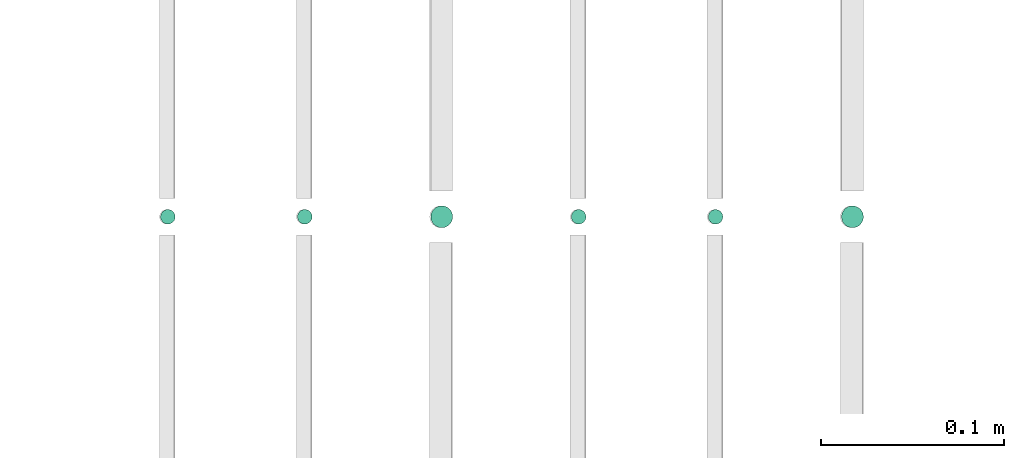
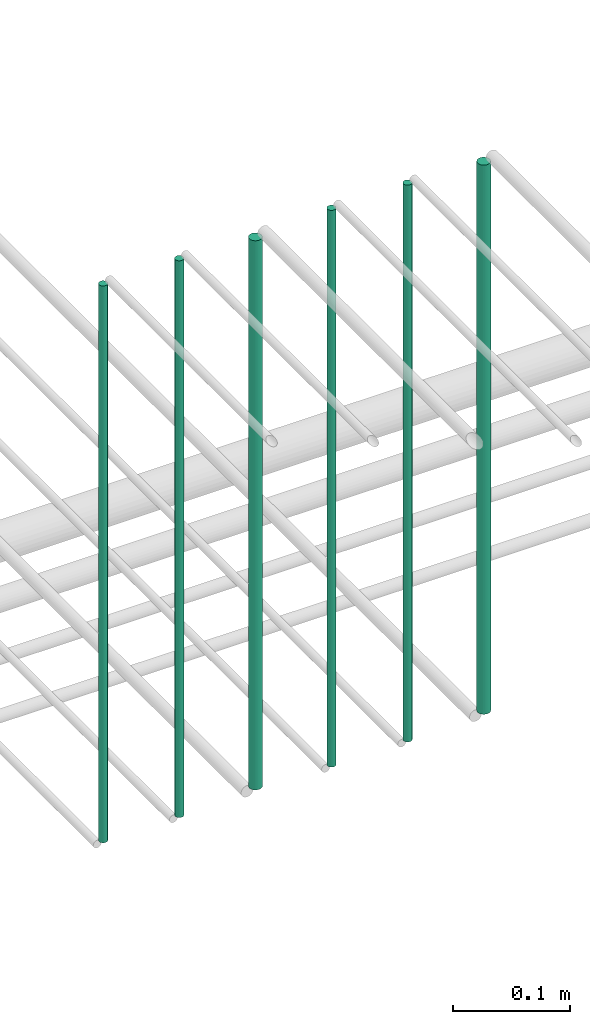
# One storey, part 194 of 331: 6 flow segments.
"""IFC2X3 building model written with IfcOpenShell, lengths in millimetres."""

from ifc_helpers import new_model, entity, si_unit, converted_unit, derived_unit, direction, frame, origin, origin_2d_with_axis, place, context, subcontext, project, spatial, circle, extrude, type_object, element, save


model = new_model("IFC2X3")

# Units and contexts
model_context = context("Model", 3, precision=0.01, world=origin(), true_north=direction((6.12303176911189e-17, 1.0)))
body_context = subcontext(model_context, "Body", "Model", "MODEL_VIEW")
ifc_project = project(units=[si_unit("LENGTHUNIT", "METRE", prefix="MILLI"), si_unit("AREAUNIT", "SQUARE_METRE"), si_unit("VOLUMEUNIT", "CUBIC_METRE"), converted_unit("PLANEANGLEUNIT", "DEGREE", entity("IfcRatioMeasure", 0.0174532925199433), si_unit("PLANEANGLEUNIT", "RADIAN"), dimensions=[0, 0, 0, 0, 0, 0, 0]), si_unit("MASSUNIT", "GRAM", prefix="KILO"), derived_unit("MASSDENSITYUNIT", [(si_unit("MASSUNIT", "GRAM", prefix="KILO"), 1), (si_unit("LENGTHUNIT", "METRE"), -3)]), derived_unit("MOMENTOFINERTIAUNIT", [(si_unit("LENGTHUNIT", "METRE"), 4)]), si_unit("TIMEUNIT", "SECOND"), si_unit("FREQUENCYUNIT", "HERTZ"), si_unit("THERMODYNAMICTEMPERATUREUNIT", "DEGREE_CELSIUS"), derived_unit("THERMALTRANSMITTANCEUNIT", [(si_unit("MASSUNIT", "GRAM", prefix="KILO"), 1), (si_unit("THERMODYNAMICTEMPERATUREUNIT", "KELVIN"), -1), (si_unit("TIMEUNIT", "SECOND"), -3)]), derived_unit("VOLUMETRICFLOWRATEUNIT", [(si_unit("LENGTHUNIT", "METRE"), 3), (si_unit("TIMEUNIT", "SECOND"), -1)]), derived_unit("MASSFLOWRATEUNIT", [(si_unit("MASSUNIT", "GRAM", prefix="KILO"), 1), (si_unit("TIMEUNIT", "SECOND"), -1)]), derived_unit("ROTATIONALFREQUENCYUNIT", [(si_unit("TIMEUNIT", "SECOND"), -1)]), si_unit("ELECTRICCURRENTUNIT", "AMPERE"), si_unit("ELECTRICVOLTAGEUNIT", "VOLT"), si_unit("POWERUNIT", "WATT"), si_unit("FORCEUNIT", "NEWTON", prefix="KILO"), si_unit("ILLUMINANCEUNIT", "LUX"), si_unit("LUMINOUSFLUXUNIT", "LUMEN"), si_unit("LUMINOUSINTENSITYUNIT", "CANDELA"), derived_unit("USERDEFINED", [(si_unit("MASSUNIT", "GRAM", prefix="KILO"), -1), (si_unit("LENGTHUNIT", "METRE"), -2), (si_unit("TIMEUNIT", "SECOND"), 3), (si_unit("LUMINOUSFLUXUNIT", "LUMEN"), 1)]), derived_unit("LINEARVELOCITYUNIT", [(si_unit("LENGTHUNIT", "METRE"), 1), (si_unit("TIMEUNIT", "SECOND"), -1)]), si_unit("PRESSUREUNIT", "PASCAL"), derived_unit("USERDEFINED", [(si_unit("LENGTHUNIT", "METRE"), -2), (si_unit("MASSUNIT", "GRAM", prefix="KILO"), 1), (si_unit("TIMEUNIT", "SECOND"), -2)]), derived_unit("LINEARFORCEUNIT", [(si_unit("MASSUNIT", "GRAM", prefix="KILO"), 1), (si_unit("LENGTHUNIT", "METRE"), 1), (si_unit("TIMEUNIT", "SECOND"), -2), (si_unit("LENGTHUNIT", "METRE"), -1)]), derived_unit("PLANARFORCEUNIT", [(si_unit("MASSUNIT", "GRAM", prefix="KILO"), 1), (si_unit("LENGTHUNIT", "METRE"), 1), (si_unit("TIMEUNIT", "SECOND"), -2), (si_unit("LENGTHUNIT", "METRE"), -2)])], contexts=[model_context])

# Site, building, storey
site_placement = place(None, frame((0.0, -0.00077364408347762, 0.0)))
site = spatial("IfcSite", under=ifc_project, at=site_placement, CompositionType="ELEMENT")
building_placement = place(site_placement, origin())
building = spatial("IfcBuilding", under=site, at=building_placement, CompositionType="ELEMENT")
storey_placement = place(building_placement, origin())
storey = spatial("IfcBuildingStorey", under=building, at=storey_placement, CompositionType="ELEMENT", Elevation=0.0)

# Flow segments
pipe_segment_type = type_object("IfcPipeSegmentType", PredefinedType="NOTDEFINED")
flow_segment_1_placement = place(storey_placement, frame((52665.0441030245, 5638.02529159143, 14560.0)))
element("IfcFlowSegment", 1, at=flow_segment_1_placement, inside=storey, type_object=pipe_segment_type, context=body_context, shape_type="SweptSolid", body=[
    extrude(circle(Radius=4.0, at=origin_2d_with_axis()), frame((5.59527223591499, 5.59527223591607, 0.0), z_axis=(0.0, 0.0, 1.0), x_axis=(-1.0, 0.0, 0.0)), (0.0, 0.0, 1.0), 580.000000000026),
])
flow_segment_2_placement = place(storey_placement, frame((52740.0441030245, 5638.02529159143, 14560.0)))
element("IfcFlowSegment", 2, at=flow_segment_2_placement, inside=storey, type_object=pipe_segment_type, context=body_context, shape_type="SweptSolid", body=[
    extrude(circle(Radius=4.0, at=origin_2d_with_axis()), frame((5.59527223591499, 5.59527223591607, 0.0), z_axis=(0.0, 0.0, 1.0), x_axis=(-1.0, 0.0, 0.0)), (0.0, 0.0, 1.0), 580.000000000009),
])
flow_segment_3_placement = place(storey_placement, frame((52813.0441030245, 5636.02529159143, 14564.0)))
element("IfcFlowSegment", 3, at=flow_segment_3_placement, inside=storey, type_object=pipe_segment_type, context=body_context, shape_type="SweptSolid", body=[
    extrude(circle(Radius=6.0, at=origin_2d_with_axis()), frame((7.59527223591454, 7.59527223591562, 0.0), z_axis=(0.0, 0.0, 1.0), x_axis=(-1.0, 0.0, 0.0)), (0.0, 0.0, 1.0), 572.0),
])
flow_segment_4_placement = place(storey_placement, frame((52890.0441030245, 5638.02529159143, 14560.0)))
element("IfcFlowSegment", 4, at=flow_segment_4_placement, inside=storey, type_object=pipe_segment_type, context=body_context, shape_type="SweptSolid", body=[
    extrude(circle(Radius=4.0, at=origin_2d_with_axis()), frame((5.59527223591499, 5.59527223591607, 0.0), z_axis=(0.0, 0.0, 1.0), x_axis=(-1.0, 0.0, 0.0)), (0.0, 0.0, 1.0), 580.000000000024),
])
flow_segment_5_placement = place(storey_placement, frame((52965.0441030245, 5638.02529159143, 14560.0)))
element("IfcFlowSegment", 5, at=flow_segment_5_placement, inside=storey, type_object=pipe_segment_type, context=body_context, shape_type="SweptSolid", body=[
    extrude(circle(Radius=4.0, at=origin_2d_with_axis()), frame((5.59527223591499, 5.59527223591607, 0.0), z_axis=(0.0, 0.0, 1.0), x_axis=(-1.0, 0.0, 0.0)), (0.0, 0.0, 1.0), 579.999999999998),
])
flow_segment_6_placement = place(storey_placement, frame((53038.0441030244, 5636.02529159143, 14564.0)))
element("IfcFlowSegment", 6, at=flow_segment_6_placement, inside=storey, type_object=pipe_segment_type, context=body_context, shape_type="SweptSolid", body=[
    extrude(circle(Radius=6.0, at=origin_2d_with_axis()), frame((7.59527223591454, 7.59527223591562, 0.0), z_axis=(0.0, 0.0, 1.0), x_axis=(-1.0, 0.0, 0.0)), (0.0, 0.0, 1.0), 572.000000000011),
])

save(model, "model.ifc")
